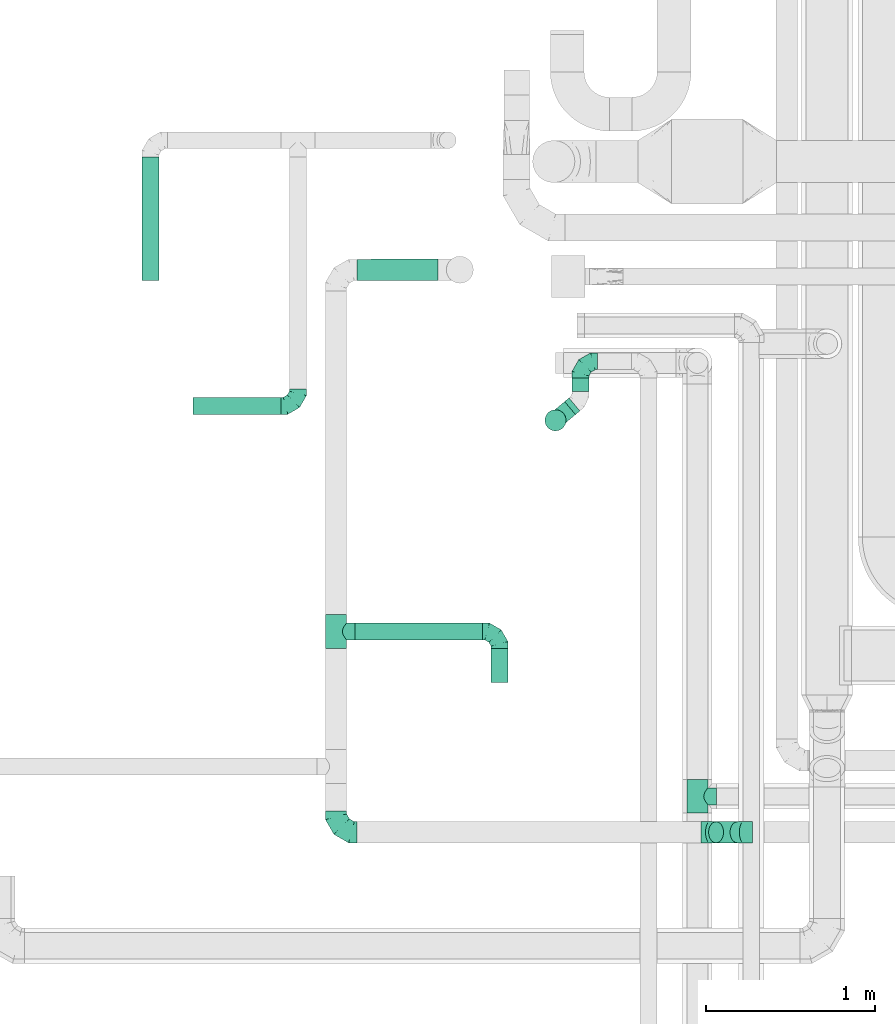
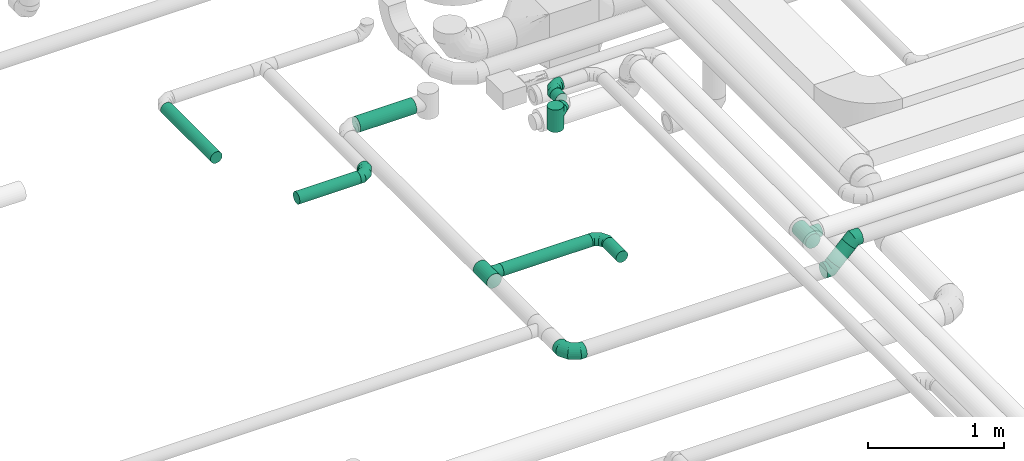
# One storey, part 66 of 92: 9 flow fittings, 8 flow segments.
"""IFC2X3 building model written with IfcOpenShell, lengths in millimetres."""

import ifcopenshell
import ifcopenshell.guid

model = None  # the IFC model being written
_history = None  # IfcOwnerHistory: only IFC2X3 demands one
_inside = {}  # id of a spatial element -> (the spatial element, [elements in it])
_under = {}  # id of a project, library or spatial element -> (it, [spatial elements below it])
_declared = {}  # id of a project -> (the project, [libraries it declares])
_typed = {}  # id of a type object -> (the type object, [elements of that type])
_made_of = {}  # id of a material, layer set ... -> (it, [elements and type objects made of it])


def new_model(schema):
    """Start an empty IFC model of exactly this schema.

    Asked for "IFC4X3", IfcOpenShell would pick the latest addendum, in which some entities
    have other attributes; the version numbers below select the first issue.
    IFC2X3 requires an IfcOwnerHistory on every rooted entity: one is made here for all.
    """
    global model, _history
    if schema == "IFC4X3":
        model = ifcopenshell.file(schema_version=(4, 3, 0, 0))
    else:
        model = ifcopenshell.file(schema=schema)
    _inside.clear()
    _under.clear()
    _declared.clear()
    _typed.clear()
    _made_of.clear()
    _history = None
    if model.schema == "IFC2X3":
        org = make("IfcOrganization", Name="unknown")
        user = make(
            "IfcPersonAndOrganization",
            ThePerson=make("IfcPerson", FamilyName="unknown"),
            TheOrganization=org,
        )
        app = make(
            "IfcApplication",
            ApplicationDeveloper=org,
            Version="unknown",
            ApplicationFullName="unknown",
            ApplicationIdentifier="unknown",
        )
        _history = make(
            "IfcOwnerHistory",
            OwningUser=user,
            OwningApplication=app,
            ChangeAction="ADDED",
            CreationDate=0,
        )
    return model


def make(cls, **values):
    """One entity of the class cls with the attributes given. An attribute that is None is left unset."""
    return model.create_entity(
        cls, **{name: value for name, value in values.items() if value is not None}
    )


def entity(cls, *values):
    """Any entity or typed value of the class cls, its attributes in the order of the schema. None: left unset."""
    e = model.create_entity(cls)
    for i, value in enumerate(values):
        if value is not None:
            e[i] = value
    return e


def rooted(cls, **values):
    """An entity with a GlobalId (a new one), such as an element, a storey or a relation."""
    return make(cls, GlobalId=ifcopenshell.guid.new(), OwnerHistory=_history, **values)


def si_unit(unit_type, name, prefix=None):
    """IfcSIUnit, for example si_unit("LENGTHUNIT", "METRE", prefix="MILLI")."""
    return make("IfcSIUnit", UnitType=unit_type, Prefix=prefix, Name=name)


def converted_unit(unit_type, name, factor, base, dimensions=None, offset=None):
    """IfcConversionBasedUnit, such as the inch: factor (a typed value) times the base unit."""
    return make(
        "IfcConversionBasedUnit"
        if offset is None
        else "IfcConversionBasedUnitWithOffset",
        ConversionOffset=offset,
        Dimensions=None
        if dimensions is None
        else entity("IfcDimensionalExponents", *dimensions),
        UnitType=unit_type,
        Name=name,
        ConversionFactor=make(
            "IfcMeasureWithUnit", ValueComponent=factor, UnitComponent=base
        ),
    )


def derived_unit(unit_type, elements):
    """IfcDerivedUnit: a product of units, each with its exponent."""
    return make(
        "IfcDerivedUnit",
        Elements=[
            make("IfcDerivedUnitElement", Unit=unit, Exponent=power)
            for unit, power in elements
        ],
        UnitType=unit_type,
    )


def assignment(units):
    """IfcUnitAssignment: the units of a project."""
    return None if units is None else make("IfcUnitAssignment", Units=units)


def point(xyz):
    """IfcCartesianPoint."""
    return None if xyz is None else make("IfcCartesianPoint", Coordinates=xyz)


def direction(xyz):
    """IfcDirection."""
    return None if xyz is None else make("IfcDirection", DirectionRatios=xyz)


def frame(location, z_axis=None, x_axis=None):
    """IfcAxis2Placement3D, a coordinate frame: its origin and axes. An axis left out is left unset."""
    return make(
        "IfcAxis2Placement3D",
        Location=point(location),
        Axis=direction(z_axis),
        RefDirection=direction(x_axis),
    )


def frame_2d(location, x_axis=None):
    """IfcAxis2Placement2D, a coordinate frame in the plane: its origin and x axis."""
    return make(
        "IfcAxis2Placement2D", Location=point(location), RefDirection=direction(x_axis)
    )


def origin():
    """The frame at (0, 0, 0) with its axes left unset."""
    return frame((0.0, 0.0, 0.0))


def origin_2d_with_axis():
    """The frame at (0, 0) in the plane with the x axis (1, 0) written out."""
    return frame_2d((0.0, 0.0), x_axis=(1.0, 0.0))


def place(relative_to, where):
    """IfcLocalPlacement: puts the frame where relative to a parent placement (None: the world)."""
    return make(
        "IfcLocalPlacement", PlacementRelTo=relative_to, RelativePlacement=where
    )


def context(
    kind, dimensions, precision=None, world=None, true_north=None, identifier=None
):
    """IfcGeometricRepresentationContext, for example the 3D "Model" context."""
    return make(
        "IfcGeometricRepresentationContext",
        ContextIdentifier=identifier,
        ContextType=kind,
        CoordinateSpaceDimension=dimensions,
        Precision=precision,
        WorldCoordinateSystem=world,
        TrueNorth=true_north,
    )


def subcontext(parent, identifier, kind, view, scale=None):
    """IfcGeometricRepresentationSubContext, for example "Body" below "Model"."""
    return make(
        "IfcGeometricRepresentationSubContext",
        ContextIdentifier=identifier,
        ContextType=kind,
        ParentContext=parent,
        TargetScale=scale,
        TargetView=view,
    )


def project(units=None, contexts=None):
    """IfcProject with its units and contexts."""
    return rooted(
        "IfcProject",
        Name="project",
        RepresentationContexts=contexts,
        UnitsInContext=assignment(units),
    )


def spatial(cls, under=None, at=None, **own):
    """A site, building, storey or space (cls), placed at a placement, below another one or the project."""
    s = rooted(cls, ObjectPlacement=at, **own)
    if under is not None:
        _under.setdefault(under.id(), (under, []))[1].append(s)
    return s


def profile(cls, at=None, kind="AREA", **sizes):
    """A parametric profile (cls). Its sizes go by their IFC names, for example OverallWidth=200.0."""
    return make(cls, ProfileType=kind, Position=at, **sizes)


def circle(**sizes):
    """IfcCircleProfileDef."""
    return profile("IfcCircleProfileDef", **sizes)


def extrude(swept, where, along, depth):
    """IfcExtrudedAreaSolid: the profile swept, set in the frame where, extruded along a direction by depth."""
    return make(
        "IfcExtrudedAreaSolid",
        SweptArea=swept,
        Position=where,
        ExtrudedDirection=direction(along),
        Depth=depth,
    )


def faces_of(points, faces, orient=None, outer=None):
    """IfcFace entities. A face is a list of loops; a loop is a list of indices into points, from 0.

    orient and outer hold one flag for each loop. By default every Orientation is true, the
    first loop of a face is its IfcFaceOuterBound and the others are IfcFaceBound.
    """
    made = []
    for i, loops in enumerate(faces):
        bounds = []
        for j, loop in enumerate(loops):
            is_outer = j == 0 if outer is None else outer[i][j]
            bounds.append(
                make(
                    "IfcFaceOuterBound" if is_outer else "IfcFaceBound",
                    Bound=make("IfcPolyLoop", Polygon=[points[k] for k in loop]),
                    Orientation=True if orient is None else orient[i][j],
                )
            )
        made.append(make("IfcFace", Bounds=bounds))
    return made


def faceted_brep(points, faces, orient=None, outer=None, voids=None):
    """IfcFacetedBrep: a solid bounded by flat faces; with voids (closed shells), ...WithVoids."""
    shared = [point(p) for p in points]
    hull = make("IfcClosedShell", CfsFaces=faces_of(shared, faces, orient, outer))
    if voids is None:
        return make("IfcFacetedBrep", Outer=hull)
    return make(
        "IfcFacetedBrepWithVoids",
        Outer=hull,
        Voids=[
            make(cls, CfsFaces=faces_of(shared, fs, o, b)) for cls, fs, o, b in voids
        ],
    )


def shape(context_of_items, identifier, shape_type, items):
    """IfcShapeRepresentation: the items that make up one representation, for example the "Body"."""
    return make(
        "IfcShapeRepresentation",
        ContextOfItems=context_of_items,
        RepresentationIdentifier=identifier,
        RepresentationType=shape_type,
        Items=items,
    )


def source(mapping_origin, context_of_items, identifier, shape_type, items):
    """IfcRepresentationMap: a shape defined once, which mapped items show again and again."""
    return make(
        "IfcRepresentationMap",
        MappingOrigin=mapping_origin,
        MappedRepresentation=shape(context_of_items, identifier, shape_type, items),
    )


def transform(
    local_origin,
    x_axis=None,
    y_axis=None,
    z_axis=None,
    scale=None,
    scale2=None,
    scale3=None,
    uniform=True,
):
    """IfcCartesianTransformationOperator3D, or its non-uniform kind. x_axis, y_axis, z_axis: its Axis1, 2, 3."""
    if uniform:
        return make(
            "IfcCartesianTransformationOperator3D",
            Axis1=direction(x_axis),
            Axis2=direction(y_axis),
            LocalOrigin=point(local_origin),
            Scale=scale,
            Axis3=direction(z_axis),
        )
    return make(
        "IfcCartesianTransformationOperator3DnonUniform",
        Axis1=direction(x_axis),
        Axis2=direction(y_axis),
        LocalOrigin=point(local_origin),
        Scale=scale,
        Axis3=direction(z_axis),
        Scale2=scale2,
        Scale3=scale3,
    )


def mapped(mapping_source, mapping_target):
    """IfcMappedItem: shows the shape of a source again, moved by a transform."""
    return make(
        "IfcMappedItem", MappingSource=mapping_source, MappingTarget=mapping_target
    )


def material(Name=None, Category=None):
    """IfcMaterial."""
    return make("IfcMaterial", Name=Name, Category=Category)


def made_of(thing, what):
    """Note that an element or type object is made of a material, layer set ...; save() writes the relation."""
    if what is not None:
        _made_of.setdefault(what.id(), (what, []))[1].append(thing)
    return thing


def type_object(cls, material=None, **own):
    """A type object (cls), such as IfcWallType, which elements share."""
    return made_of(rooted(cls, **own), material)


def type_shapes(of_type, sources):
    """Give a type object the sources (RepresentationMaps) that its elements show as mapped items."""
    of_type.RepresentationMaps = sources


def element(
    cls,
    number,
    at=None,
    inside=None,
    cuts=None,
    type_object=None,
    material=None,
    context=None,
    identifier="Body",
    shape_type=None,
    held_by="IfcProductDefinitionShape",
    body=None,
    shapes=None,
    **own,
):
    """One element of the class cls, such as IfcWall. Its Tag is "e" and its number.

    at: its placement. inside: the storey or other place that contains it. cuts: it is an
    opening in that element (IfcRelVoidsElement). A single representation is given by context,
    identifier, shape_type and body (its items); several are given by shapes. held_by: the class
    of the entity that holds the representations. save() writes the other relations.
    """
    e = rooted(cls, Tag="e%d" % number, ObjectPlacement=at, **own)
    if body is not None:
        shapes = [shape(context, identifier, shape_type, body)]
    if shapes is not None:
        e.Representation = make(held_by, Representations=shapes)
    if inside is not None:
        _inside.setdefault(inside.id(), (inside, []))[1].append(e)
    if cuts is not None:
        rooted(
            "IfcRelVoidsElement", RelatingBuildingElement=cuts, RelatedOpeningElement=e
        )
    if type_object is not None:
        _typed.setdefault(type_object.id(), (type_object, []))[1].append(e)
    return made_of(e, material)


def aggregate(whole, parts):
    """IfcRelAggregates: a whole, such as a stair, and the parts it consists of."""
    return rooted("IfcRelAggregates", RelatingObject=whole, RelatedObjects=parts)


def save(model, path):
    """Write the relations noted so far, then the file.

    IfcRelAggregates (storeys below a building ...), IfcRelContainedInSpatialStructure (elements
    in a storey), IfcRelDefinesByType, IfcRelAssociatesMaterial and IfcRelDeclares: one each for
    every whole, place, type object, material and project.
    """
    for whole, parts in _under.values():
        aggregate(whole, parts)
    for where, things in _inside.values():
        rooted(
            "IfcRelContainedInSpatialStructure",
            RelatedElements=things,
            RelatingStructure=where,
        )
    for kind, things in _typed.values():
        rooted("IfcRelDefinesByType", RelatedObjects=things, RelatingType=kind)
    for what, things in _made_of.values():
        rooted("IfcRelAssociatesMaterial", RelatedObjects=things, RelatingMaterial=what)
    for by, libraries in _declared.values():
        rooted("IfcRelDeclares", RelatingContext=by, RelatedDefinitions=libraries)
    model.write(path)


model = new_model("IFC2X3")

# Units and contexts
model_context = context("Model", 3, precision=0.01, world=origin(), true_north=direction((6.12303176911189e-17, 1.0)))
body_context = subcontext(model_context, "Body", "Model", "MODEL_VIEW")
ifc_project = project(units=[si_unit("LENGTHUNIT", "METRE", prefix="MILLI"), si_unit("AREAUNIT", "SQUARE_METRE"), si_unit("VOLUMEUNIT", "CUBIC_METRE"), converted_unit("PLANEANGLEUNIT", "DEGREE", entity("IfcRatioMeasure", 0.0174532925199433), si_unit("PLANEANGLEUNIT", "RADIAN"), dimensions=[0, 0, 0, 0, 0, 0, 0]), si_unit("MASSUNIT", "GRAM", prefix="KILO"), derived_unit("MASSDENSITYUNIT", [(si_unit("MASSUNIT", "GRAM", prefix="KILO"), 1), (si_unit("LENGTHUNIT", "METRE"), -3)]), derived_unit("MOMENTOFINERTIAUNIT", [(si_unit("LENGTHUNIT", "METRE"), 4)]), si_unit("TIMEUNIT", "SECOND"), si_unit("FREQUENCYUNIT", "HERTZ"), si_unit("THERMODYNAMICTEMPERATUREUNIT", "DEGREE_CELSIUS"), derived_unit("THERMALTRANSMITTANCEUNIT", [(si_unit("MASSUNIT", "GRAM", prefix="KILO"), 1), (si_unit("THERMODYNAMICTEMPERATUREUNIT", "KELVIN"), -1), (si_unit("TIMEUNIT", "SECOND"), -3)]), derived_unit("VOLUMETRICFLOWRATEUNIT", [(si_unit("LENGTHUNIT", "METRE"), 3), (si_unit("TIMEUNIT", "SECOND"), -1)]), derived_unit("MASSFLOWRATEUNIT", [(si_unit("MASSUNIT", "GRAM", prefix="KILO"), 1), (si_unit("TIMEUNIT", "SECOND"), -1)]), derived_unit("ROTATIONALFREQUENCYUNIT", [(si_unit("TIMEUNIT", "SECOND"), -1)]), si_unit("ELECTRICCURRENTUNIT", "AMPERE"), si_unit("ELECTRICVOLTAGEUNIT", "VOLT"), si_unit("POWERUNIT", "WATT"), si_unit("FORCEUNIT", "NEWTON", prefix="KILO"), si_unit("ILLUMINANCEUNIT", "LUX"), si_unit("LUMINOUSFLUXUNIT", "LUMEN"), si_unit("LUMINOUSINTENSITYUNIT", "CANDELA"), derived_unit("USERDEFINED", [(si_unit("MASSUNIT", "GRAM", prefix="KILO"), -1), (si_unit("LENGTHUNIT", "METRE"), -2), (si_unit("TIMEUNIT", "SECOND"), 3), (si_unit("LUMINOUSFLUXUNIT", "LUMEN"), 1)]), derived_unit("LINEARVELOCITYUNIT", [(si_unit("LENGTHUNIT", "METRE"), 1), (si_unit("TIMEUNIT", "SECOND"), -1)]), si_unit("PRESSUREUNIT", "PASCAL"), derived_unit("USERDEFINED", [(si_unit("LENGTHUNIT", "METRE"), -2), (si_unit("MASSUNIT", "GRAM", prefix="KILO"), 1), (si_unit("TIMEUNIT", "SECOND"), -2)]), derived_unit("LINEARFORCEUNIT", [(si_unit("MASSUNIT", "GRAM", prefix="KILO"), 1), (si_unit("LENGTHUNIT", "METRE"), 1), (si_unit("TIMEUNIT", "SECOND"), -2), (si_unit("LENGTHUNIT", "METRE"), -1)]), derived_unit("PLANARFORCEUNIT", [(si_unit("MASSUNIT", "GRAM", prefix="KILO"), 1), (si_unit("LENGTHUNIT", "METRE"), 1), (si_unit("TIMEUNIT", "SECOND"), -2), (si_unit("LENGTHUNIT", "METRE"), -2)])], contexts=[model_context])

# Site, building, storey
site_placement = place(None, origin())
site = spatial("IfcSite", under=ifc_project, at=site_placement, CompositionType="ELEMENT")
building_placement = place(site_placement, origin())
building = spatial("IfcBuilding", under=site, at=building_placement, CompositionType="ELEMENT")
storey_placement = place(building_placement, frame((0.0, 0.0, 4200.0)))
storey = spatial("IfcBuildingStorey", under=building, at=storey_placement, CompositionType="ELEMENT", Elevation=4200.0)

# Flow segments
duct_segment_type = type_object("IfcDuctSegmentType", PredefinedType="NOTDEFINED")
flow_segment_1_placement = place(storey_placement, frame((58308.38, 11789.66, 3085.9)))
element("IfcFlowSegment", 1, at=flow_segment_1_placement, inside=storey, type_object=duct_segment_type, context=body_context, shape_type="SweptSolid", body=[
    extrude(circle(Radius=62.5, at=origin_2d_with_axis()), frame((0.06, 64.1, 64.1), z_axis=(0.99999951635307, 0.000983510867822962, 0.0), x_axis=(0.000983510867822962, -0.99999951635307, 0.0)), (0.0, 0.0, 1.0), 477.196853588731),
])
flow_segment_2_placement = place(storey_placement, frame((58296.06, 9665.11, 3098.4)))
element("IfcFlowSegment", 2, at=flow_segment_2_placement, inside=storey, type_object=duct_segment_type, context=body_context, shape_type="SweptSolid", body=[
    extrude(circle(Radius=50.0, at=origin_2d_with_axis()), frame((0.0, 51.6, 51.6), z_axis=(1.0, 0.0, 0.0), x_axis=(0.0, -1.0, 0.0)), (0.0, 0.0, 1.0), 753.822304408238),
])
flow_segment_3_placement = place(storey_placement, frame((59098.29, 9416.71, 3098.4)))
element("IfcFlowSegment", 3, at=flow_segment_3_placement, inside=storey, type_object=duct_segment_type, context=body_context, shape_type="SweptSolid", body=[
    extrude(circle(Radius=50.0, at=origin_2d_with_axis()), frame((51.6, 0.0, 51.6), z_axis=(0.0, 1.0, 0.0), x_axis=(-1.0, 0.0, 0.0)), (0.0, 0.0, 1.0), 200.000000000007),
])
flow_segment_4_placement = place(storey_placement, frame((57035.97, 11789.72, 3268.4)))
element("IfcFlowSegment", 4, at=flow_segment_4_placement, inside=storey, type_object=duct_segment_type, context=body_context, shape_type="SweptSolid", body=[
    extrude(circle(Radius=50.0, at=origin_2d_with_axis()), frame((51.6, 0.0, 51.6), z_axis=(0.0, 1.0, 0.0), x_axis=(-1.0, 0.0, 0.0)), (0.0, 0.0, 1.0), 730.000000000007),
])
flow_segment_5_placement = place(storey_placement, frame((57338.56, 10998.72, 3268.4)))
element("IfcFlowSegment", 5, at=flow_segment_5_placement, inside=storey, type_object=duct_segment_type, context=body_context, shape_type="SweptSolid", body=[
    extrude(circle(Radius=50.0, at=origin_2d_with_axis()), frame((0.0, 51.6, 51.6), z_axis=(1.0, 0.0, 0.0), x_axis=(0.0, 1.0, 0.0)), (0.0, 0.0, 1.0), 520.000000000003),
])
flow_segment_6_placement = place(storey_placement, frame((60383.58, 8466.04, 3140.82)))
element("IfcFlowSegment", 6, at=flow_segment_6_placement, inside=storey, type_object=duct_segment_type, context=body_context, shape_type="SweptSolid", body=[
    extrude(circle(Radius=62.5, at=origin_2d_with_axis()), frame((45.79, 64.1, 45.79), z_axis=(0.707106781186487, 0.0, 0.707106781186609), x_axis=(0.0, 1.0, 0.0)), (0.0, 0.0, 1.0), 179.289321881373),
])
flow_segment_7_placement = place(storey_placement, frame((59576.65, 11135.11, 3298.4)))
element("IfcFlowSegment", 7, at=flow_segment_7_placement, inside=storey, type_object=duct_segment_type, context=body_context, shape_type="SweptSolid", body=[
    extrude(circle(Radius=50.0, at=origin_2d_with_axis()), frame((51.6, 0.0, 51.6), z_axis=(0.0, 1.0, 0.0), x_axis=(-1.0, 0.0, 0.0)), (0.0, 0.0, 1.0), 78.3425078517259),
])
flow_segment_8_placement = place(storey_placement, frame((59533.05, 10996.99, 3298.4)))
element("IfcFlowSegment", 8, at=flow_segment_8_placement, inside=storey, type_object=duct_segment_type, context=body_context, shape_type="SweptSolid", body=[
    extrude(circle(Radius=50.0, at=origin_2d_with_axis()), frame((33.72, 39.91, 51.6), z_axis=(0.766326560722248, 0.642451245100833, 0.0), x_axis=(0.642451245100833, -0.766326560722248, 0.0)), (0.0, 0.0, 1.0), 33.5703050726903),
])

# Flow fittings
ifc_material = material()
duct_fitting_type_1 = type_object("IfcDuctFittingType", PredefinedType="NOTDEFINED", material=ifc_material)
shared_shape_1 = source(origin(), body_context, "Body", "Brep", [
    faceted_brep([(-100.0, 0.0, -50.0), (-100.0, -12.94, -48.3), (-100.0, -25.0, -43.3), (-100.0, -35.36, -35.36), (-100.0, -43.3, -25.0), (-100.0, -48.3, -12.94), (-100.0, -50.0, 0.0), (-100.0, -48.3, 12.94), (-100.0, -43.3, 25.0), (-100.0, -35.36, 35.36), (-100.0, -25.0, 43.3), (-100.0, -12.94, 48.3), (-100.0, 0.0, 50.0), (-100.0, 12.94, 48.3), (-100.0, 25.0, 43.3), (-100.0, 35.36, 35.36), (-100.0, 43.3, 25.0), (-100.0, 48.3, 12.94), (-100.0, 50.0, 0.0), (-100.0, 48.3, -12.94), (-100.0, 43.3, -25.0), (-100.0, 35.36, -35.36), (-100.0, 25.0, -43.3), (-100.0, 12.94, -48.3), (-76.67, 12.94, 48.3), (-79.9, 25.0, 43.3), (-73.21, 0.0, 50.0), (-82.68, 35.36, 35.36), (-86.15, 48.3, 12.94), (-86.6, 50.0, 0.0), (-84.81, 43.3, 25.0), (-84.81, 43.3, -25.0), (-82.68, 35.36, -35.36), (-86.15, 48.3, -12.94), (-76.67, 12.94, -48.3), (-73.21, 0.0, -50.0), (-79.9, 25.0, -43.3), (-69.74, -12.94, -48.3), (-66.51, -25.0, -43.3), (-63.73, -35.36, -35.36), (-61.6, -43.3, -25.0), (-60.26, -48.3, -12.94), (-59.81, -50.0, 0.0), (-60.26, -48.3, 12.94), (-61.6, -43.3, 25.0), (-63.73, -35.36, 35.36), (-66.51, -25.0, 43.3), (-69.74, -12.94, 48.3), (-36.27, 36.27, 48.3), (-45.1, 45.1, 43.3), (-26.79, 26.79, 50.0), (-52.68, 52.68, 35.36), (-58.49, 58.49, 25.0), (-62.15, 62.15, 12.94), (-63.4, 63.4, 0.0), (-62.15, 62.15, -12.94), (-58.49, 58.49, -25.0), (-52.68, 52.68, -35.36), (-36.27, 36.27, -48.3), (-26.79, 26.79, -50.0), (-45.1, 45.1, -43.3), (-17.32, 17.32, -48.3), (-8.49, 8.49, -43.3), (-0.91, 0.91, -35.36), (4.9, -4.9, -25.0), (8.56, -8.56, -12.94), (9.81, -9.81, 0.0), (8.56, -8.56, 12.94), (4.9, -4.9, 25.0), (-0.91, 0.91, 35.36), (-8.49, 8.49, 43.3), (-17.32, 17.32, 48.3), (-12.94, 76.67, 48.3), (-25.0, 79.9, 43.3), (0.0, 73.21, 50.0), (-35.36, 82.68, 35.36), (-43.3, 84.81, 25.0), (-48.3, 86.15, 12.94), (-50.0, 86.6, 0.0), (-48.3, 86.15, -12.94), (-43.3, 84.81, -25.0), (-35.36, 82.68, -35.36), (-12.94, 76.67, -48.3), (0.0, 73.21, -50.0), (-25.0, 79.9, -43.3), (12.94, 69.74, -48.3), (25.0, 66.51, -43.3), (35.36, 63.73, -35.36), (43.3, 61.6, -25.0), (48.3, 60.26, -12.94), (50.0, 59.81, 0.0), (48.3, 60.26, 12.94), (43.3, 61.6, 25.0), (35.36, 63.73, 35.36), (25.0, 66.51, 43.3), (12.94, 69.74, 48.3), (-12.94, 100.0, -48.3), (-25.0, 100.0, -43.3), (-35.36, 100.0, -35.36), (-43.3, 100.0, -25.0), (-48.3, 100.0, -12.94), (-50.0, 100.0, 0.0), (-48.3, 100.0, 12.94), (-43.3, 100.0, 25.0), (-35.36, 100.0, 35.36), (-25.0, 100.0, 43.3), (-12.94, 100.0, 48.3), (0.0, 100.0, 50.0), (12.94, 100.0, 48.3), (25.0, 100.0, 43.3), (35.36, 100.0, 35.36), (43.3, 100.0, 25.0), (48.3, 100.0, 12.94), (50.0, 100.0, 0.0), (48.3, 100.0, -12.94), (43.3, 100.0, -25.0), (35.36, 100.0, -35.36), (25.0, 100.0, -43.3), (12.94, 100.0, -48.3), (0.0, 100.0, -50.0)], [[[0, 1, 2, 3, 4, 5, 6, 7, 8, 9, 10, 11, 12, 13, 14, 15, 16, 17, 18, 19, 20, 21, 22, 23]], [[24, 25, 14, 13]], [[26, 24, 13, 12]], [[14, 25, 27, 15]], [[28, 29, 18, 17]], [[30, 28, 17, 16]], [[15, 27, 30, 16]], [[20, 31, 32, 21]], [[33, 31, 20, 19]], [[18, 29, 33, 19]], [[34, 35, 0, 23]], [[36, 34, 23, 22]], [[32, 36, 22, 21]], [[2, 1, 37, 38]], [[3, 2, 38, 39]], [[0, 35, 37, 1]], [[5, 4, 40, 41]], [[6, 5, 41, 42]], [[3, 39, 40, 4]], [[6, 42, 43, 7]], [[7, 43, 44, 8]], [[8, 44, 45, 9]], [[10, 46, 47, 11]], [[11, 47, 26, 12]], [[10, 9, 45, 46]], [[48, 49, 25, 24]], [[50, 48, 24, 26]], [[27, 25, 49, 51]], [[52, 53, 28, 30]], [[51, 52, 30, 27]], [[29, 28, 53, 54]], [[55, 56, 31, 33]], [[54, 55, 33, 29]], [[57, 32, 31, 56]], [[58, 59, 35, 34]], [[60, 58, 34, 36]], [[57, 60, 36, 32]], [[37, 35, 59, 61]], [[38, 37, 61, 62]], [[39, 38, 62, 63]], [[41, 40, 64, 65]], [[42, 41, 65, 66]], [[63, 64, 40, 39]], [[43, 42, 66, 67]], [[44, 43, 67, 68]], [[68, 69, 45, 44]], [[46, 45, 69, 70]], [[47, 46, 70, 71]], [[26, 47, 71, 50]], [[72, 73, 49, 48]], [[74, 72, 48, 50]], [[51, 49, 73, 75]], [[76, 77, 53, 52]], [[75, 76, 52, 51]], [[54, 53, 77, 78]], [[79, 80, 56, 55]], [[78, 79, 55, 54]], [[81, 57, 56, 80]], [[82, 83, 59, 58]], [[84, 82, 58, 60]], [[81, 84, 60, 57]], [[61, 59, 83, 85]], [[62, 61, 85, 86]], [[63, 62, 86, 87]], [[65, 64, 88, 89]], [[66, 65, 89, 90]], [[87, 88, 64, 63]], [[67, 66, 90, 91]], [[68, 67, 91, 92]], [[92, 93, 69, 68]], [[70, 69, 93, 94]], [[71, 70, 94, 95]], [[50, 71, 95, 74]], [[96, 97, 98, 99, 100, 101, 102, 103, 104, 105, 106, 107, 108, 109, 110, 111, 112, 113, 114, 115, 116, 117, 118, 119]], [[72, 74, 107, 106]], [[73, 72, 106, 105]], [[75, 73, 105, 104]], [[77, 76, 103, 102]], [[78, 77, 102, 101]], [[75, 104, 103, 76]], [[78, 101, 100, 79]], [[79, 100, 99, 80]], [[80, 99, 98, 81]], [[96, 119, 83, 82]], [[97, 96, 82, 84]], [[84, 81, 98, 97]], [[83, 119, 118, 85]], [[85, 118, 117, 86]], [[86, 117, 116, 87]], [[88, 115, 114, 89]], [[89, 114, 113, 90]], [[87, 116, 115, 88]], [[91, 90, 113, 112]], [[92, 91, 112, 111]], [[93, 92, 111, 110]], [[95, 94, 109, 108]], [[74, 95, 108, 107]], [[110, 109, 94, 93]]]),
])
type_shapes(duct_fitting_type_1, [shared_shape_1])
flow_fitting_1_placement = place(storey_placement, frame((59149.88, 9716.71, 3150.0), z_axis=(0.0, 0.0, 1.0), x_axis=(0.0, 1.0, 0.0)))
element("IfcFlowFitting", 9, at=flow_fitting_1_placement, inside=storey, type_object=duct_fitting_type_1, material=ifc_material, context=body_context, shape_type="MappedRepresentation", body=[
    mapped(shared_shape_1, transform((0.0, 0.0, 0.0), scale=1.0)),
])
flow_fitting_2_placement = place(storey_placement, frame((57958.56, 11050.32, 3320.0)))
element("IfcFlowFitting", 10, at=flow_fitting_2_placement, inside=storey, type_object=duct_fitting_type_1, material=ifc_material, context=body_context, shape_type="MappedRepresentation", body=[
    mapped(shared_shape_1, transform((0.0, 0.0, 0.0), scale=1.0)),
])
flow_fitting_3_placement = place(storey_placement, frame((59628.25, 11313.45, 3350.0), z_axis=(0.0, 0.0, 1.0), x_axis=(-1.0, 0.0, 0.0)))
element("IfcFlowFitting", 11, at=flow_fitting_3_placement, inside=storey, type_object=duct_fitting_type_1, material=ifc_material, context=body_context, shape_type="MappedRepresentation", body=[
    mapped(shared_shape_1, transform((0.0, 0.0, 0.0), scale=1.0)),
])
duct_fitting_type_2 = type_object("IfcDuctFittingType", PredefinedType="NOTDEFINED", material=ifc_material)
shared_shape_2 = source(origin(), body_context, "Body", "Brep", [
    faceted_brep([(-125.0, 0.0, -62.5), (-125.0, -16.18, -60.37), (-125.0, -31.25, -54.13), (-125.0, -44.19, -44.19), (-125.0, -54.13, -31.25), (-125.0, -60.37, -16.18), (-125.0, -62.5, 0.0), (-125.0, -60.37, 16.18), (-125.0, -54.13, 31.25), (-125.0, -44.19, 44.19), (-125.0, -31.25, 54.13), (-125.0, -16.18, 60.37), (-125.0, 0.0, 62.5), (-125.0, 16.18, 60.37), (-125.0, 31.25, 54.13), (-125.0, 44.19, 44.19), (-125.0, 54.13, 31.25), (-125.0, 60.37, 16.18), (-125.0, 62.5, 0.0), (-125.0, 60.37, -16.18), (-125.0, 54.13, -31.25), (-125.0, 44.19, -44.19), (-125.0, 31.25, -54.13), (-125.0, 16.18, -60.37), (-95.84, 16.18, 60.37), (-99.88, 31.25, 54.13), (-91.51, 0.0, 62.5), (-103.35, 44.19, 44.19), (-107.68, 60.37, 16.18), (-108.25, 62.5, 0.0), (-106.01, 54.13, 31.25), (-106.01, 54.13, -31.25), (-103.35, 44.19, -44.19), (-107.68, 60.37, -16.18), (-95.84, 16.18, -60.37), (-91.51, 0.0, -62.5), (-99.88, 31.25, -54.13), (-87.17, -16.18, -60.37), (-83.13, -31.25, -54.13), (-79.66, -44.19, -44.19), (-77.0, -54.13, -31.25), (-75.33, -60.37, -16.18), (-74.76, -62.5, 0.0), (-75.33, -60.37, 16.18), (-77.0, -54.13, 31.25), (-79.66, -44.19, 44.19), (-83.13, -31.25, 54.13), (-87.17, -16.18, 60.37), (-45.34, 45.34, 60.37), (-56.37, 56.37, 54.13), (-33.49, 33.49, 62.5), (-65.85, 65.85, 44.19), (-73.12, 73.12, 31.25), (-77.69, 77.69, 16.18), (-79.25, 79.25, 0.0), (-77.69, 77.69, -16.18), (-73.12, 73.12, -31.25), (-65.85, 65.85, -44.19), (-45.34, 45.34, -60.37), (-33.49, 33.49, -62.5), (-56.37, 56.37, -54.13), (-21.65, 21.65, -60.37), (-10.62, 10.62, -54.13), (-1.14, 1.14, -44.19), (6.13, -6.13, -31.25), (10.7, -10.7, -16.18), (12.26, -12.26, 0.0), (10.7, -10.7, 16.18), (6.13, -6.13, 31.25), (-1.14, 1.14, 44.19), (-10.62, 10.62, 54.13), (-21.65, 21.65, 60.37), (-16.18, 95.84, 60.37), (-31.25, 99.88, 54.13), (0.0, 91.51, 62.5), (-44.19, 103.35, 44.19), (-54.13, 106.01, 31.25), (-60.37, 107.68, 16.18), (-62.5, 108.25, 0.0), (-60.37, 107.68, -16.18), (-54.13, 106.01, -31.25), (-44.19, 103.35, -44.19), (-16.18, 95.84, -60.37), (0.0, 91.51, -62.5), (-31.25, 99.88, -54.13), (16.18, 87.17, -60.37), (31.25, 83.13, -54.13), (44.19, 79.66, -44.19), (54.13, 77.0, -31.25), (60.37, 75.33, -16.18), (62.5, 74.76, 0.0), (60.37, 75.33, 16.18), (54.13, 77.0, 31.25), (44.19, 79.66, 44.19), (31.25, 83.13, 54.13), (16.18, 87.17, 60.37), (-16.18, 125.0, -60.37), (-31.25, 125.0, -54.13), (-44.19, 125.0, -44.19), (-54.13, 125.0, -31.25), (-60.37, 125.0, -16.18), (-62.5, 125.0, 0.0), (-60.37, 125.0, 16.18), (-54.13, 125.0, 31.25), (-44.19, 125.0, 44.19), (-31.25, 125.0, 54.13), (-16.18, 125.0, 60.37), (0.0, 125.0, 62.5), (16.18, 125.0, 60.37), (31.25, 125.0, 54.13), (44.19, 125.0, 44.19), (54.13, 125.0, 31.25), (60.37, 125.0, 16.18), (62.5, 125.0, 0.0), (60.37, 125.0, -16.18), (54.13, 125.0, -31.25), (44.19, 125.0, -44.19), (31.25, 125.0, -54.13), (16.18, 125.0, -60.37), (0.0, 125.0, -62.5)], [[[0, 1, 2, 3, 4, 5, 6, 7, 8, 9, 10, 11, 12, 13, 14, 15, 16, 17, 18, 19, 20, 21, 22, 23]], [[24, 25, 14, 13]], [[26, 24, 13, 12]], [[14, 25, 27, 15]], [[28, 29, 18, 17]], [[30, 28, 17, 16]], [[15, 27, 30, 16]], [[20, 31, 32, 21]], [[33, 31, 20, 19]], [[18, 29, 33, 19]], [[34, 35, 0, 23]], [[36, 34, 23, 22]], [[21, 32, 36, 22]], [[1, 0, 35, 37]], [[2, 1, 37, 38]], [[38, 39, 3, 2]], [[5, 4, 40, 41]], [[6, 5, 41, 42]], [[39, 40, 4, 3]], [[6, 42, 43, 7]], [[7, 43, 44, 8]], [[45, 9, 8, 44]], [[9, 45, 46, 10]], [[10, 46, 47, 11]], [[26, 12, 11, 47]], [[48, 49, 25, 24]], [[50, 48, 24, 26]], [[27, 25, 49, 51]], [[52, 53, 28, 30]], [[51, 52, 30, 27]], [[29, 28, 53, 54]], [[55, 56, 31, 33]], [[54, 55, 33, 29]], [[57, 32, 31, 56]], [[58, 59, 35, 34]], [[60, 58, 34, 36]], [[57, 60, 36, 32]], [[37, 35, 59, 61]], [[38, 37, 61, 62]], [[39, 38, 62, 63]], [[41, 40, 64, 65]], [[42, 41, 65, 66]], [[63, 64, 40, 39]], [[43, 42, 66, 67]], [[44, 43, 67, 68]], [[68, 69, 45, 44]], [[46, 45, 69, 70]], [[47, 46, 70, 71]], [[26, 47, 71, 50]], [[72, 73, 49, 48]], [[74, 72, 48, 50]], [[51, 49, 73, 75]], [[76, 77, 53, 52]], [[75, 76, 52, 51]], [[54, 53, 77, 78]], [[79, 80, 56, 55]], [[78, 79, 55, 54]], [[81, 57, 56, 80]], [[82, 83, 59, 58]], [[84, 82, 58, 60]], [[81, 84, 60, 57]], [[61, 59, 83, 85]], [[62, 61, 85, 86]], [[63, 62, 86, 87]], [[65, 64, 88, 89]], [[66, 65, 89, 90]], [[87, 88, 64, 63]], [[67, 66, 90, 91]], [[68, 67, 91, 92]], [[92, 93, 69, 68]], [[70, 69, 93, 94]], [[71, 70, 94, 95]], [[50, 71, 95, 74]], [[96, 97, 98, 99, 100, 101, 102, 103, 104, 105, 106, 107, 108, 109, 110, 111, 112, 113, 114, 115, 116, 117, 118, 119]], [[72, 74, 107, 106]], [[73, 72, 106, 105]], [[75, 73, 105, 104]], [[77, 76, 103, 102]], [[78, 77, 102, 101]], [[75, 104, 103, 76]], [[78, 101, 100, 79]], [[79, 100, 99, 80]], [[80, 99, 98, 81]], [[96, 119, 83, 82]], [[97, 96, 82, 84]], [[84, 81, 98, 97]], [[83, 119, 118, 85]], [[85, 118, 117, 86]], [[116, 87, 86, 117]], [[88, 115, 114, 89]], [[89, 114, 113, 90]], [[115, 88, 87, 116]], [[91, 90, 113, 112]], [[92, 91, 112, 111]], [[111, 110, 93, 92]], [[95, 94, 109, 108]], [[74, 95, 108, 107]], [[110, 109, 94, 93]]]),
])
type_shapes(duct_fitting_type_2, [shared_shape_2])
flow_fitting_4_placement = place(storey_placement, frame((58183.56, 8530.14, 3150.0), z_axis=(0.0, 0.0, 1.0), x_axis=(0.0, -1.0, 0.0)))
element("IfcFlowFitting", 12, at=flow_fitting_4_placement, inside=storey, type_object=duct_fitting_type_2, material=ifc_material, context=body_context, shape_type="MappedRepresentation", body=[
    mapped(shared_shape_2, transform((0.0, 0.0, 0.0), scale=1.0)),
])
duct_fitting_type_3 = type_object("IfcDuctFittingType", PredefinedType="NOTDEFINED", material=ifc_material)
shared_shape_3 = source(origin(), body_context, "Body", "Brep", [
    faceted_brep([(-51.78, 0.0, -62.5), (-51.78, -16.18, -60.37), (-51.78, -31.25, -54.13), (-51.78, -44.19, -44.19), (-51.78, -54.13, -31.25), (-51.78, -60.37, -16.18), (-51.78, -62.5, 0.0), (-51.78, -60.37, 16.18), (-51.78, -54.13, 31.25), (-51.78, -44.19, 44.19), (-51.78, -31.25, 54.13), (-51.78, -16.18, 60.37), (-51.78, 0.0, 62.5), (-51.78, 16.18, 60.37), (-51.78, 31.25, 54.13), (-51.78, 44.19, 44.19), (-51.78, 54.13, 31.25), (-51.78, 60.37, 16.18), (-51.78, 62.5, 0.0), (-51.78, 60.37, -16.18), (-51.78, 54.13, -31.25), (-51.78, 44.19, -44.19), (-51.78, 31.25, -54.13), (-51.78, 16.18, -60.37), (-6.7, 16.18, 60.37), (-12.94, 31.25, 54.13), (0.0, 0.0, 62.5), (-18.31, 44.19, 44.19), (-22.42, 54.13, 31.25), (-25.01, 60.37, 16.18), (-25.89, 62.5, 0.0), (-25.01, 60.37, -16.18), (-22.42, 54.13, -31.25), (-18.31, 44.19, -44.19), (-6.7, 16.18, -60.37), (0.0, 0.0, -62.5), (-12.94, 31.25, -54.13), (6.7, -16.18, -60.37), (12.94, -31.25, -54.13), (18.31, -44.19, -44.19), (22.42, -54.13, -31.25), (25.01, -60.37, -16.18), (25.89, -62.5, 0.0), (25.01, -60.37, 16.18), (22.42, -54.13, 31.25), (18.31, -44.19, 44.19), (12.94, -31.25, 54.13), (6.7, -16.18, 60.37), (25.17, 48.05, 60.37), (14.51, 58.71, 54.13), (36.61, 36.61, 62.5), (5.36, 67.86, 44.19), (-1.66, 74.88, 31.25), (-6.08, 79.3, 16.18), (-7.58, 80.81, 0.0), (-6.08, 79.3, -16.18), (-1.66, 74.88, -31.25), (5.36, 67.86, -44.19), (14.51, 58.71, -54.13), (25.17, 48.05, -60.37), (36.61, 36.61, -62.5), (48.05, 25.17, -60.37), (58.71, 14.51, -54.13), (67.86, 5.36, -44.19), (74.88, -1.66, -31.25), (79.3, -6.08, -16.18), (80.81, -7.58, 0.0), (79.3, -6.08, 16.18), (74.88, -1.66, 31.25), (67.86, 5.36, 44.19), (58.71, 14.51, 54.13), (48.05, 25.17, 60.37)], [[[0, 1, 2, 3, 4, 5, 6, 7, 8, 9, 10, 11, 12, 13, 14, 15, 16, 17, 18, 19, 20, 21, 22, 23]], [[24, 25, 14, 13]], [[26, 24, 13, 12]], [[27, 15, 14, 25]], [[28, 29, 17, 16]], [[28, 16, 15, 27]], [[30, 18, 17, 29]], [[31, 32, 20, 19]], [[30, 31, 19, 18]], [[21, 20, 32, 33]], [[34, 35, 0, 23]], [[36, 34, 23, 22]], [[33, 36, 22, 21]], [[1, 0, 35, 37]], [[2, 1, 37, 38]], [[38, 39, 3, 2]], [[5, 4, 40, 41]], [[6, 5, 41, 42]], [[39, 40, 4, 3]], [[6, 42, 43, 7]], [[7, 43, 44, 8]], [[8, 44, 45, 9]], [[9, 45, 46, 10]], [[10, 46, 47, 11]], [[26, 12, 11, 47]], [[48, 49, 25, 24]], [[50, 48, 24, 26]], [[27, 25, 49, 51]], [[29, 28, 52, 53]], [[30, 29, 53, 54]], [[51, 52, 28, 27]], [[30, 54, 55, 31]], [[31, 55, 56, 32]], [[57, 33, 32, 56]], [[36, 58, 59, 34]], [[34, 59, 60, 35]], [[58, 36, 33, 57]], [[35, 60, 61, 37]], [[37, 61, 62, 38]], [[63, 39, 38, 62]], [[40, 64, 65, 41]], [[41, 65, 66, 42]], [[64, 40, 39, 63]], [[43, 42, 66, 67]], [[44, 43, 67, 68]], [[68, 69, 45, 44]], [[47, 46, 70, 71]], [[26, 47, 71, 50]], [[69, 70, 46, 45]], [[59, 58, 57, 56, 55, 54, 53, 52, 51, 49, 48, 50, 71, 70, 69, 68, 67, 66, 65, 64, 63, 62, 61, 60]]]),
])
type_shapes(duct_fitting_type_3, [shared_shape_3])
for number, where, z_axis, x_axis in (
    (13, (60592.75, 8530.14, 3350.0), (0.0, 1.0, 0.0), (0.70710678118649, 0.0, 0.707106781186605)),
    (14, (60392.75, 8530.14, 3150.0), (0.0, 1.0, 0.0), (-0.70710678118649, 0.0, -0.707106781186605)),
):
    element("IfcFlowFitting", number, at=place(storey_placement, frame(where, z_axis=z_axis, x_axis=x_axis)), inside=storey, type_object=duct_fitting_type_3, material=ifc_material, context=body_context, shape_type="MappedRepresentation", body=[
        mapped(shared_shape_3, transform((0.0, 0.0, 0.0), scale=1.0)),
    ])
duct_fitting_type_4 = type_object("IfcDuctFittingType", PredefinedType="NOTDEFINED", material=ifc_material)
shared_shape_4 = source(origin(), body_context, "Body", "Brep", [
    faceted_brep([(12.94, -112.5, -48.3), (25.0, -112.5, -43.3), (35.36, -112.5, -35.36), (43.3, -112.5, -25.0), (48.3, -112.5, -12.94), (50.0, -112.5, 0.0), (48.3, -112.5, 12.94), (43.3, -112.5, 25.0), (35.36, -112.5, 35.36), (25.0, -112.5, 43.3), (12.94, -112.5, 48.3), (0.0, -112.5, 50.0), (-12.94, -112.5, 48.3), (-25.0, -112.5, 43.3), (-35.36, -112.5, 35.36), (-43.3, -112.5, 25.0), (-48.3, -112.5, 12.94), (-50.0, -112.5, 0.0), (-48.3, -112.5, -12.94), (-43.3, -112.5, -25.0), (-35.36, -112.5, -35.36), (-25.0, -112.5, -43.3), (-12.94, -112.5, -48.3), (0.0, -112.5, -50.0), (10.22, -38.87, 48.94), (19.57, -42.3, 46.01), (27.84, -46.7, 41.53), (35.05, -51.33, 35.66), (0.0, -37.5, 50.0), (41.13, -55.66, 28.43), (45.86, -59.24, 19.92), (48.93, -61.65, 10.29), (50.0, -62.5, 0.0), (44.67, -58.32, -22.47), (48.61, -61.39, -11.71), (38.68, -53.87, -31.69), (31.07, -48.7, -39.18), (22.05, -43.5, -44.88), (11.62, -39.26, -48.63), (0.0, -37.5, -50.0), (-10.22, -38.87, -48.94), (-19.57, -42.3, -46.01), (-27.84, -46.7, -41.53), (-35.05, -51.33, -35.66), (-41.13, -55.66, -28.43), (-45.86, -59.24, -19.92), (-48.93, -61.65, -10.29), (-50.0, -62.5, 0.0), (-48.93, -61.65, 10.29), (-45.86, -59.24, 19.92), (-41.13, -55.66, 28.43), (-35.05, -51.33, 35.66), (-27.84, -46.7, 41.53), (-19.57, -42.3, 46.01), (-10.22, -38.87, 48.94), (-100.0, 0.0, -62.5), (-100.0, -16.18, -60.37), (-100.0, -31.25, -54.13), (-100.0, -44.19, -44.19), (-100.0, -49.16, -37.72), (-100.0, -54.13, -31.25), (-100.0, -57.25, -23.71), (-100.0, -60.37, -16.18), (-100.0, -61.44, -8.09), (-100.0, -62.5, 0.0), (-100.0, -61.44, 8.09), (-100.0, -60.37, 16.18), (-100.0, -57.25, 23.71), (-100.0, -54.13, 31.25), (-100.0, -49.16, 37.72), (-100.0, -44.19, 44.19), (-100.0, -31.25, 54.13), (-100.0, -16.18, 60.37), (-100.0, 0.0, 62.5), (-100.0, 16.18, 60.37), (-100.0, 31.25, 54.13), (-100.0, 44.19, 44.19), (-100.0, 54.13, 31.25), (-100.0, 60.37, 16.18), (-100.0, 62.5, 0.0), (-100.0, 60.37, -16.18), (-100.0, 54.13, -31.25), (-100.0, 44.19, -44.19), (-100.0, 31.25, -54.13), (-100.0, 16.18, -60.37), (100.0, 16.18, -60.37), (100.0, 31.25, -54.13), (100.0, 44.19, -44.19), (100.0, 54.13, -31.25), (100.0, 60.37, -16.18), (100.0, 62.5, 0.0), (100.0, 60.37, 16.18), (100.0, 54.13, 31.25), (100.0, 44.19, 44.19), (100.0, 31.25, 54.13), (100.0, 16.18, 60.37), (100.0, 0.0, 62.5), (100.0, -16.18, 60.37), (100.0, -31.25, 54.13), (100.0, -44.19, 44.19), (100.0, -49.16, 37.72), (100.0, -54.13, 31.25), (100.0, -57.25, 23.71), (100.0, -60.37, 16.18), (100.0, -61.44, 8.09), (100.0, -62.5, 0.0), (100.0, -61.44, -8.09), (100.0, -60.37, -16.18), (100.0, -57.25, -23.71), (100.0, -54.13, -31.25), (100.0, -49.16, -37.72), (100.0, -44.19, -44.19), (100.0, -31.25, -54.13), (100.0, -16.18, -60.37), (100.0, 0.0, -62.5)], [[[0, 1, 2, 3, 4, 5, 6, 7, 8, 9, 10, 11, 12, 13, 14, 15, 16, 17, 18, 19, 20, 21, 22, 23]], [[24, 11, 10]], [[10, 9, 25]], [[8, 26, 9]], [[8, 27, 26]], [[28, 11, 24]], [[24, 10, 25]], [[9, 26, 25]], [[29, 8, 7]], [[30, 7, 6]], [[31, 6, 5]], [[30, 29, 7]], [[32, 31, 5]], [[30, 6, 31]], [[8, 29, 27]], [[4, 3, 33]], [[5, 4, 34]], [[34, 32, 5]], [[35, 33, 3]], [[34, 4, 33]], [[3, 2, 35]], [[36, 2, 1]], [[37, 1, 0]], [[38, 0, 23]], [[36, 1, 37]], [[38, 37, 0]], [[39, 38, 23]], [[2, 36, 35]], [[40, 23, 22]], [[22, 21, 41]], [[20, 42, 21]], [[20, 43, 42]], [[39, 23, 40]], [[40, 22, 41]], [[21, 42, 41]], [[44, 20, 19]], [[45, 19, 18]], [[46, 18, 17]], [[45, 44, 19]], [[47, 46, 17]], [[45, 18, 46]], [[20, 44, 43]], [[48, 17, 16]], [[49, 16, 15]], [[50, 15, 14]], [[48, 47, 17]], [[50, 49, 15]], [[48, 16, 49]], [[14, 51, 50]], [[51, 14, 52]], [[52, 14, 13]], [[53, 13, 12]], [[54, 12, 11]], [[52, 13, 53]], [[54, 53, 12]], [[28, 54, 11]], [[55, 56, 57, 58, 59, 60, 61, 62, 63, 64, 65, 66, 67, 68, 69, 70, 71, 72, 73, 74, 75, 76, 77, 78, 79, 80, 81, 82, 83, 84]], [[85, 86, 87, 88, 89, 90, 91, 92, 93, 94, 95, 96, 97, 98, 99, 100, 101, 102, 103, 104, 105, 106, 107, 108, 109, 110, 111, 112, 113, 114]], [[74, 73, 96, 95]], [[75, 74, 95, 94]], [[94, 93, 76, 75]], [[78, 77, 92, 91]], [[79, 78, 91, 90]], [[93, 92, 77, 76]], [[89, 88, 81, 80]], [[90, 89, 80, 79]], [[88, 87, 82, 81]], [[84, 83, 86, 85]], [[55, 84, 85, 114]], [[87, 86, 83, 82]], [[113, 56, 55, 114]], [[112, 57, 56, 113]], [[111, 36, 37]], [[110, 109, 35]], [[43, 60, 59]], [[37, 38, 111]], [[35, 108, 33]], [[111, 38, 112]], [[38, 39, 112]], [[112, 39, 57]], [[39, 40, 57]], [[40, 41, 58]], [[47, 63, 46]], [[59, 42, 43]], [[42, 58, 41]], [[45, 62, 61]], [[40, 58, 57]], [[36, 111, 110]], [[34, 107, 106]], [[109, 108, 35]], [[33, 108, 107]], [[105, 32, 106]], [[47, 64, 63]], [[34, 106, 32]], [[107, 34, 33]], [[43, 44, 60]], [[44, 61, 60]], [[61, 44, 45]], [[59, 58, 42]], [[63, 62, 46]], [[46, 62, 45]], [[36, 110, 35]], [[105, 104, 32]], [[64, 47, 65]], [[31, 104, 103]], [[101, 29, 102]], [[30, 102, 29]], [[103, 30, 31]], [[48, 65, 47]], [[48, 49, 66]], [[50, 51, 68]], [[49, 67, 66]], [[67, 50, 68]], [[51, 69, 68]], [[29, 101, 27]], [[100, 26, 27]], [[26, 100, 99]], [[27, 101, 100]], [[25, 26, 99]], [[99, 24, 25]], [[32, 104, 31]], [[72, 71, 98, 97]], [[28, 24, 98]], [[98, 24, 99]], [[97, 96, 73, 72]], [[50, 67, 49]], [[53, 54, 70]], [[48, 66, 65]], [[69, 52, 70]], [[70, 52, 53]], [[54, 71, 70]], [[30, 103, 102]], [[28, 71, 54]], [[28, 98, 71]], [[52, 69, 51]]]),
])
type_shapes(duct_fitting_type_4, [shared_shape_4])
for number, where, z_axis, x_axis in (
    (15, (58183.56, 9716.71, 3150.0), (0.0, 0.0, 1.0), (0.0, 1.0, 0.0)),
    (16, (60318.95, 8742.68, 3350.0), (0.0, 0.0, 1.0), (0.0, 1.0, 0.0)),
    (17, (59480.56, 10964.63, 3350.0), (-0.64245124510071, 0.766326560722351, 0.0), (0.0, 0.0, -1.0)),
):
    element("IfcFlowFitting", number, at=place(storey_placement, frame(where, z_axis=z_axis, x_axis=x_axis)), inside=storey, type_object=duct_fitting_type_4, material=ifc_material, context=body_context, shape_type="MappedRepresentation", body=[
        mapped(shared_shape_4, transform((0.0, 0.0, 0.0), scale=1.0)),
    ])

save(model, "model.ifc")
